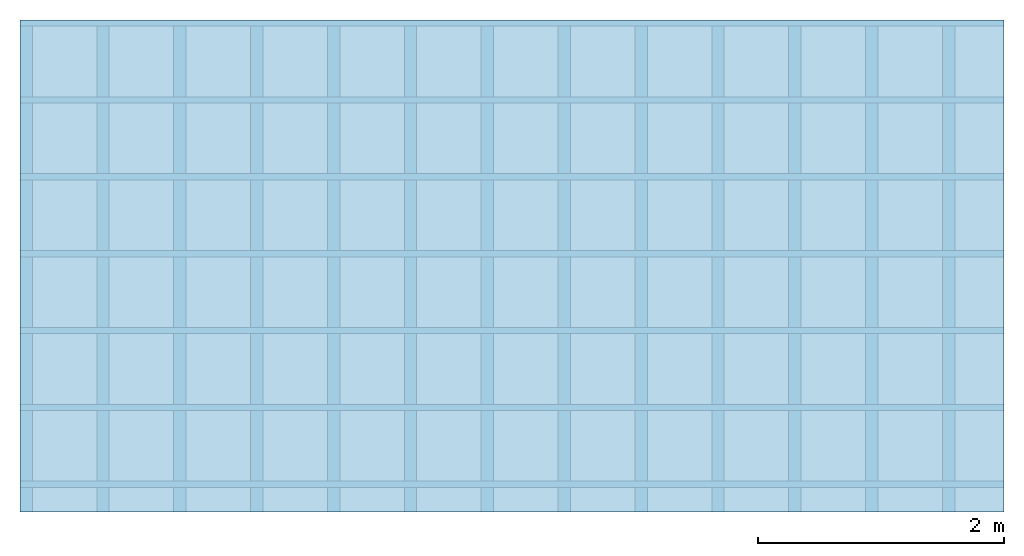
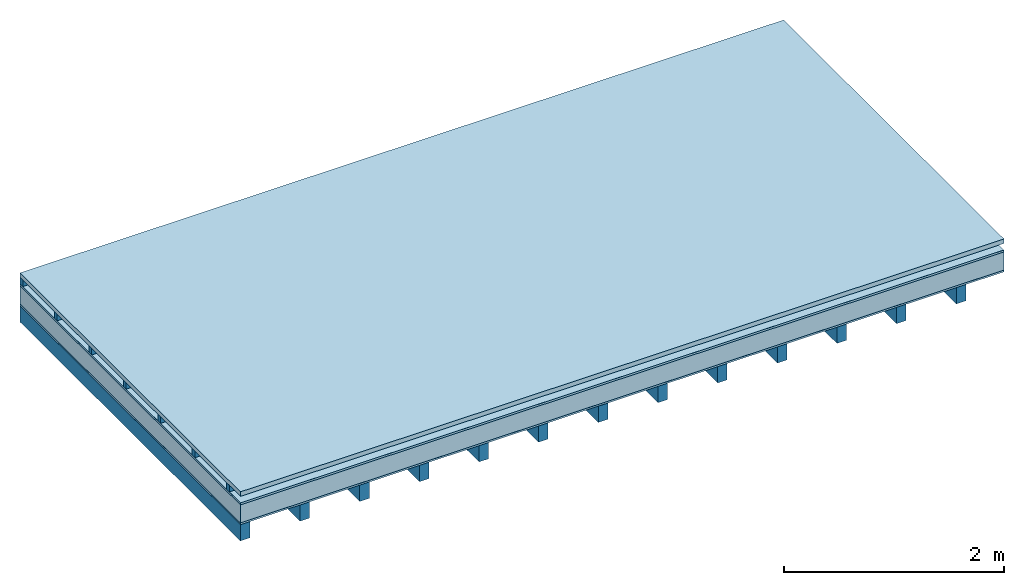
# One storey: 6 plates, 2 members, 1 element without a shape of its own.
"""IFC4 building model written with IfcOpenShell, lengths in metres."""

import ifcopenshell
import ifcopenshell.guid

model = None  # the IFC model being written
_history = None  # IfcOwnerHistory: only IFC2X3 demands one
_inside = {}  # id of a spatial element -> (the spatial element, [elements in it])
_under = {}  # id of a project, library or spatial element -> (it, [spatial elements below it])
_declared = {}  # id of a project -> (the project, [libraries it declares])
_typed = {}  # id of a type object -> (the type object, [elements of that type])
_made_of = {}  # id of a material, layer set ... -> (it, [elements and type objects made of it])


def new_model(schema):
    """Start an empty IFC model of exactly this schema.

    Asked for "IFC4X3", IfcOpenShell would pick the latest addendum, in which some entities
    have other attributes; the version numbers below select the first issue.
    IFC2X3 requires an IfcOwnerHistory on every rooted entity: one is made here for all.
    """
    global model, _history
    if schema == "IFC4X3":
        model = ifcopenshell.file(schema_version=(4, 3, 0, 0))
    else:
        model = ifcopenshell.file(schema=schema)
    _inside.clear()
    _under.clear()
    _declared.clear()
    _typed.clear()
    _made_of.clear()
    _history = None
    if model.schema == "IFC2X3":
        org = make("IfcOrganization", Name="unknown")
        user = make(
            "IfcPersonAndOrganization",
            ThePerson=make("IfcPerson", FamilyName="unknown"),
            TheOrganization=org,
        )
        app = make(
            "IfcApplication",
            ApplicationDeveloper=org,
            Version="unknown",
            ApplicationFullName="unknown",
            ApplicationIdentifier="unknown",
        )
        _history = make(
            "IfcOwnerHistory",
            OwningUser=user,
            OwningApplication=app,
            ChangeAction="ADDED",
            CreationDate=0,
        )
    return model


def make(cls, **values):
    """One entity of the class cls with the attributes given. An attribute that is None is left unset."""
    return model.create_entity(
        cls, **{name: value for name, value in values.items() if value is not None}
    )


def rooted(cls, **values):
    """An entity with a GlobalId (a new one), such as an element, a storey or a relation."""
    return make(cls, GlobalId=ifcopenshell.guid.new(), OwnerHistory=_history, **values)


def si_unit(unit_type, name, prefix=None):
    """IfcSIUnit, for example si_unit("LENGTHUNIT", "METRE", prefix="MILLI")."""
    return make("IfcSIUnit", UnitType=unit_type, Prefix=prefix, Name=name)


def derived_unit(unit_type, elements):
    """IfcDerivedUnit: a product of units, each with its exponent."""
    return make(
        "IfcDerivedUnit",
        Elements=[
            make("IfcDerivedUnitElement", Unit=unit, Exponent=power)
            for unit, power in elements
        ],
        UnitType=unit_type,
    )


def assignment(units):
    """IfcUnitAssignment: the units of a project."""
    return None if units is None else make("IfcUnitAssignment", Units=units)


def point(xyz):
    """IfcCartesianPoint."""
    return None if xyz is None else make("IfcCartesianPoint", Coordinates=xyz)


def direction(xyz):
    """IfcDirection."""
    return None if xyz is None else make("IfcDirection", DirectionRatios=xyz)


def frame(location, z_axis=None, x_axis=None):
    """IfcAxis2Placement3D, a coordinate frame: its origin and axes. An axis left out is left unset."""
    return make(
        "IfcAxis2Placement3D",
        Location=point(location),
        Axis=direction(z_axis),
        RefDirection=direction(x_axis),
    )


def frame_2d(location, x_axis=None):
    """IfcAxis2Placement2D, a coordinate frame in the plane: its origin and x axis."""
    return make(
        "IfcAxis2Placement2D", Location=point(location), RefDirection=direction(x_axis)
    )


def origin():
    """The frame at (0, 0, 0) with its axes left unset."""
    return frame((0.0, 0.0, 0.0))


def origin_with_axes():
    """The frame at (0, 0, 0) with the z axis (0, 0, 1) and the x axis (1, 0, 0) written out."""
    return frame((0.0, 0.0, 0.0), z_axis=(0.0, 0.0, 1.0), x_axis=(1.0, 0.0, 0.0))


def place(relative_to, where):
    """IfcLocalPlacement: puts the frame where relative to a parent placement (None: the world)."""
    return make(
        "IfcLocalPlacement", PlacementRelTo=relative_to, RelativePlacement=where
    )


def context(
    kind, dimensions, precision=None, world=None, true_north=None, identifier=None
):
    """IfcGeometricRepresentationContext, for example the 3D "Model" context."""
    return make(
        "IfcGeometricRepresentationContext",
        ContextIdentifier=identifier,
        ContextType=kind,
        CoordinateSpaceDimension=dimensions,
        Precision=precision,
        WorldCoordinateSystem=world,
        TrueNorth=true_north,
    )


def project(units=None, contexts=None):
    """IfcProject with its units and contexts."""
    return rooted(
        "IfcProject",
        Name="project",
        RepresentationContexts=contexts,
        UnitsInContext=assignment(units),
    )


def spatial(cls, under=None, at=None, **own):
    """A site, building, storey or space (cls), placed at a placement, below another one or the project."""
    s = rooted(cls, ObjectPlacement=at, **own)
    if under is not None:
        _under.setdefault(under.id(), (under, []))[1].append(s)
    return s


def profile(cls, at=None, kind="AREA", **sizes):
    """A parametric profile (cls). Its sizes go by their IFC names, for example OverallWidth=200.0."""
    return make(cls, ProfileType=kind, Position=at, **sizes)


def rectangle(**sizes):
    """IfcRectangleProfileDef."""
    return profile("IfcRectangleProfileDef", **sizes)


def extrude(swept, where, along, depth):
    """IfcExtrudedAreaSolid: the profile swept, set in the frame where, extruded along a direction by depth."""
    return make(
        "IfcExtrudedAreaSolid",
        SweptArea=swept,
        Position=where,
        ExtrudedDirection=direction(along),
        Depth=depth,
    )


def shape(context_of_items, identifier, shape_type, items):
    """IfcShapeRepresentation: the items that make up one representation, for example the "Body"."""
    return make(
        "IfcShapeRepresentation",
        ContextOfItems=context_of_items,
        RepresentationIdentifier=identifier,
        RepresentationType=shape_type,
        Items=items,
    )


def material(Name=None, Category=None):
    """IfcMaterial."""
    return make("IfcMaterial", Name=Name, Category=Category)


def layer(
    of_material, thickness, ventilated=None, Name=None, Category=None, Priority=None
):
    """IfcMaterialLayer: one layer of a wall or slab, of a material (None: an air gap)."""
    return make(
        "IfcMaterialLayer",
        Material=of_material,
        LayerThickness=thickness,
        IsVentilated=ventilated,
        Name=Name,
        Category=Category,
        Priority=Priority,
    )


def layer_set(layers, Name=None):
    """IfcMaterialLayerSet."""
    return make("IfcMaterialLayerSet", MaterialLayers=layers, LayerSetName=Name)


def made_of(thing, what):
    """Note that an element or type object is made of a material, layer set ...; save() writes the relation."""
    if what is not None:
        _made_of.setdefault(what.id(), (what, []))[1].append(thing)
    return thing


def type_object(cls, material=None, **own):
    """A type object (cls), such as IfcWallType, which elements share."""
    return made_of(rooted(cls, **own), material)


def element(
    cls,
    number,
    at=None,
    inside=None,
    cuts=None,
    type_object=None,
    material=None,
    context=None,
    identifier="Body",
    shape_type=None,
    held_by="IfcProductDefinitionShape",
    body=None,
    shapes=None,
    **own,
):
    """One element of the class cls, such as IfcWall. Its Tag is "e" and its number.

    at: its placement. inside: the storey or other place that contains it. cuts: it is an
    opening in that element (IfcRelVoidsElement). A single representation is given by context,
    identifier, shape_type and body (its items); several are given by shapes. held_by: the class
    of the entity that holds the representations. save() writes the other relations.
    """
    e = rooted(cls, Tag="e%d" % number, ObjectPlacement=at, **own)
    if body is not None:
        shapes = [shape(context, identifier, shape_type, body)]
    if shapes is not None:
        e.Representation = make(held_by, Representations=shapes)
    if inside is not None:
        _inside.setdefault(inside.id(), (inside, []))[1].append(e)
    if cuts is not None:
        rooted(
            "IfcRelVoidsElement", RelatingBuildingElement=cuts, RelatedOpeningElement=e
        )
    if type_object is not None:
        _typed.setdefault(type_object.id(), (type_object, []))[1].append(e)
    return made_of(e, material)


def aggregate(whole, parts):
    """IfcRelAggregates: a whole, such as a stair, and the parts it consists of."""
    return rooted("IfcRelAggregates", RelatingObject=whole, RelatedObjects=parts)


def save(model, path):
    """Write the relations noted so far, then the file.

    IfcRelAggregates (storeys below a building ...), IfcRelContainedInSpatialStructure (elements
    in a storey), IfcRelDefinesByType, IfcRelAssociatesMaterial and IfcRelDeclares: one each for
    every whole, place, type object, material and project.
    """
    for whole, parts in _under.values():
        aggregate(whole, parts)
    for where, things in _inside.values():
        rooted(
            "IfcRelContainedInSpatialStructure",
            RelatedElements=things,
            RelatingStructure=where,
        )
    for kind, things in _typed.values():
        rooted("IfcRelDefinesByType", RelatedObjects=things, RelatingType=kind)
    for what, things in _made_of.values():
        rooted("IfcRelAssociatesMaterial", RelatedObjects=things, RelatingMaterial=what)
    for by, libraries in _declared.values():
        rooted("IfcRelDeclares", RelatingContext=by, RelatedDefinitions=libraries)
    model.write(path)


model = new_model("IFC4")

# Units and contexts
plan_context = context("Plan", 3, precision=1e-05, world=origin(), true_north=direction((0.0, 1.0)))
model_context = context("Model", 3, precision=1e-05, world=origin(), true_north=direction((0.0, 1.0)))
ifc_project = project(units=[si_unit("LENGTHUNIT", "METRE"), derived_unit("SOUNDPRESSUREUNIT", [(si_unit("PRESSUREUNIT", "PASCAL", prefix="MICRO"), 0)]), si_unit("ENERGYUNIT", "JOULE", prefix="MEGA"), si_unit("MASSUNIT", "GRAM", prefix="KILO"), derived_unit("THERMALTRANSMITTANCEUNIT", [(si_unit("POWERUNIT", "WATT"), 1), (si_unit("AREAUNIT", "SQUARE_METRE"), -1), (si_unit("THERMODYNAMICTEMPERATUREUNIT", "KELVIN"), -1)]), derived_unit("AREADENSITYUNIT", [(si_unit("MASSUNIT", "GRAM", prefix="KILO"), 1), (si_unit("AREAUNIT", "SQUARE_METRE"), -1)]), derived_unit("USERDEFINED", [(si_unit("ENERGYUNIT", "JOULE", prefix="MEGA"), 1), (si_unit("AREAUNIT", "SQUARE_METRE"), -1)])], contexts=[plan_context, model_context])

# Site, building, storey
site = spatial("IfcSite", under=ifc_project)
building_placement = place(None, origin())
building = spatial("IfcBuilding", under=site, at=building_placement)
storey_placement = place(building_placement, origin())
storey = spatial("IfcBuildingStorey", under=building, at=storey_placement)

# Slab, members, plates
ifc_material_1 = material(Name="Roof tiles", Category="03.015")
ifc_layer_1 = layer(ifc_material_1, 0.05, Name="Roofing")
ifc_layer_2 = layer(None, 0.072, Name="Battens / profiles")
ifc_material_2 = material(Name="Roofing underlay", Category="09.008")
ifc_layer_3 = layer(ifc_material_2, 0.00018, Name="Under the roof")
ifc_material_3 = material(Category="10.009")
ifc_layer_4 = layer(ifc_material_3, 0.022, Name="Exterior insulation layer 2")
ifc_material_4 = material(Category="10.008")
ifc_layer_5 = layer(ifc_material_4, 0.2, Name="Exterior insulation layer 1")
ifc_material_5 = material(Name="Vapor barrier polyethylene (PE)", Category="09.002")
ifc_layer_6 = layer(ifc_material_5, 0.00018, Name="above 1st layer")
ifc_material_6 = material(Name="Boards with edges", Category="07.009")
ifc_layer_7 = layer(ifc_material_6, 0.02, Name="Sub-floor")
ifc_material_7 = material(Name="of the art")
ifc_layer_8 = layer(ifc_material_7, 0.0, Name="Bond")
ifc_layer_9 = layer(None, 0.18, Name="Supporting structure")
ifc_layer_set = layer_set([ifc_layer_1, ifc_layer_2, ifc_layer_3, ifc_layer_4, ifc_layer_5, ifc_layer_6, ifc_layer_7, ifc_layer_8, ifc_layer_9])
slab_type = type_object("IfcSlabType", Name="E0168", PredefinedType="NOTDEFINED", material=ifc_layer_set)
slab_placement = place(None, frame((0.0, 0.0, 0.0), z_axis=(0.0, 0.0, -1.0), x_axis=(1.0, 0.0, 0.0)))
slab = element("IfcSlab", 1, at=slab_placement, inside=storey, type_object=slab_type, material=ifc_layer_set, Name="Slab #1")
ifc_material_8 = material()
member_1_placement = place(slab_placement, origin())
member_1 = element("IfcMember", 2, at=member_1_placement, material=ifc_material_8, Name="Battens / profiles", context=plan_context, shape_type="SweptSolid", body=[
    extrude(rectangle(XDim=0.05, YDim=0.072, at=frame_2d((0.025, 0.036), x_axis=(1.0, 0.0))), frame((0.0, 0.0, 0.05), z_axis=(1.0, 0.0, 0.0), x_axis=(0.0, 1.0, 0.0)), (0.0, 0.0, 1.0), 8.0),
    extrude(rectangle(XDim=0.05, YDim=0.072, at=frame_2d((0.025, 0.036), x_axis=(1.0, 0.0))), frame((0.0, 0.625, 0.05), z_axis=(1.0, 0.0, 0.0), x_axis=(0.0, 1.0, 0.0)), (0.0, 0.0, 1.0), 8.0),
    extrude(rectangle(XDim=0.05, YDim=0.072, at=frame_2d((0.025, 0.036), x_axis=(1.0, 0.0))), frame((0.0, 1.25, 0.05), z_axis=(1.0, 0.0, 0.0), x_axis=(0.0, 1.0, 0.0)), (0.0, 0.0, 1.0), 8.0),
    extrude(rectangle(XDim=0.05, YDim=0.072, at=frame_2d((0.025, 0.036), x_axis=(1.0, 0.0))), frame((0.0, 1.875, 0.05), z_axis=(1.0, 0.0, 0.0), x_axis=(0.0, 1.0, 0.0)), (0.0, 0.0, 1.0), 8.0),
    extrude(rectangle(XDim=0.05, YDim=0.072, at=frame_2d((0.025, 0.036), x_axis=(1.0, 0.0))), frame((0.0, 2.5, 0.05), z_axis=(1.0, 0.0, 0.0), x_axis=(0.0, 1.0, 0.0)), (0.0, 0.0, 1.0), 8.0),
    extrude(rectangle(XDim=0.05, YDim=0.072, at=frame_2d((0.025, 0.036), x_axis=(1.0, 0.0))), frame((0.0, 3.125, 0.05), z_axis=(1.0, 0.0, 0.0), x_axis=(0.0, 1.0, 0.0)), (0.0, 0.0, 1.0), 8.0),
    extrude(rectangle(XDim=0.05, YDim=0.072, at=frame_2d((0.025, 0.036), x_axis=(1.0, 0.0))), frame((0.0, 3.75, 0.05), z_axis=(1.0, 0.0, 0.0), x_axis=(0.0, 1.0, 0.0)), (0.0, 0.0, 1.0), 8.0),
])
ifc_material_9 = material()
member_2_placement = place(slab_placement, origin())
member_2 = element("IfcMember", 3, at=member_2_placement, material=ifc_material_9, Name="Supporting structure", context=plan_context, shape_type="SweptSolid", body=[
    extrude(rectangle(XDim=0.1, YDim=0.18, at=frame_2d((0.05, 0.09), x_axis=(1.0, 0.0))), frame((0.0, 4.0, 0.36436), z_axis=(0.0, -1.0, 0.0), x_axis=(1.0, 0.0, 0.0)), (0.0, 0.0, 1.0), 4.0),
    extrude(rectangle(XDim=0.1, YDim=0.18, at=frame_2d((0.05, 0.09), x_axis=(1.0, 0.0))), frame((0.625, 4.0, 0.36436), z_axis=(0.0, -1.0, 0.0), x_axis=(1.0, 0.0, 0.0)), (0.0, 0.0, 1.0), 4.0),
    extrude(rectangle(XDim=0.1, YDim=0.18, at=frame_2d((0.05, 0.09), x_axis=(1.0, 0.0))), frame((1.25, 4.0, 0.36436), z_axis=(0.0, -1.0, 0.0), x_axis=(1.0, 0.0, 0.0)), (0.0, 0.0, 1.0), 4.0),
    extrude(rectangle(XDim=0.1, YDim=0.18, at=frame_2d((0.05, 0.09), x_axis=(1.0, 0.0))), frame((1.875, 4.0, 0.36436), z_axis=(0.0, -1.0, 0.0), x_axis=(1.0, 0.0, 0.0)), (0.0, 0.0, 1.0), 4.0),
    extrude(rectangle(XDim=0.1, YDim=0.18, at=frame_2d((0.05, 0.09), x_axis=(1.0, 0.0))), frame((2.5, 4.0, 0.36436), z_axis=(0.0, -1.0, 0.0), x_axis=(1.0, 0.0, 0.0)), (0.0, 0.0, 1.0), 4.0),
    extrude(rectangle(XDim=0.1, YDim=0.18, at=frame_2d((0.05, 0.09), x_axis=(1.0, 0.0))), frame((3.125, 4.0, 0.36436), z_axis=(0.0, -1.0, 0.0), x_axis=(1.0, 0.0, 0.0)), (0.0, 0.0, 1.0), 4.0),
    extrude(rectangle(XDim=0.1, YDim=0.18, at=frame_2d((0.05, 0.09), x_axis=(1.0, 0.0))), frame((3.75, 4.0, 0.36436), z_axis=(0.0, -1.0, 0.0), x_axis=(1.0, 0.0, 0.0)), (0.0, 0.0, 1.0), 4.0),
    extrude(rectangle(XDim=0.1, YDim=0.18, at=frame_2d((0.05, 0.09), x_axis=(1.0, 0.0))), frame((4.375, 4.0, 0.36436), z_axis=(0.0, -1.0, 0.0), x_axis=(1.0, 0.0, 0.0)), (0.0, 0.0, 1.0), 4.0),
    extrude(rectangle(XDim=0.1, YDim=0.18, at=frame_2d((0.05, 0.09), x_axis=(1.0, 0.0))), frame((5.0, 4.0, 0.36436), z_axis=(0.0, -1.0, 0.0), x_axis=(1.0, 0.0, 0.0)), (0.0, 0.0, 1.0), 4.0),
    extrude(rectangle(XDim=0.1, YDim=0.18, at=frame_2d((0.05, 0.09), x_axis=(1.0, 0.0))), frame((5.625, 4.0, 0.36436), z_axis=(0.0, -1.0, 0.0), x_axis=(1.0, 0.0, 0.0)), (0.0, 0.0, 1.0), 4.0),
    extrude(rectangle(XDim=0.1, YDim=0.18, at=frame_2d((0.05, 0.09), x_axis=(1.0, 0.0))), frame((6.25, 4.0, 0.36436), z_axis=(0.0, -1.0, 0.0), x_axis=(1.0, 0.0, 0.0)), (0.0, 0.0, 1.0), 4.0),
    extrude(rectangle(XDim=0.1, YDim=0.18, at=frame_2d((0.05, 0.09), x_axis=(1.0, 0.0))), frame((6.875, 4.0, 0.36436), z_axis=(0.0, -1.0, 0.0), x_axis=(1.0, 0.0, 0.0)), (0.0, 0.0, 1.0), 4.0),
    extrude(rectangle(XDim=0.1, YDim=0.18, at=frame_2d((0.05, 0.09), x_axis=(1.0, 0.0))), frame((7.5, 4.0, 0.36436), z_axis=(0.0, -1.0, 0.0), x_axis=(1.0, 0.0, 0.0)), (0.0, 0.0, 1.0), 4.0),
])
plate_1_placement = place(slab_placement, origin())
plate_1 = element("IfcPlate", 4, at=plate_1_placement, material=ifc_material_1, Name="Roofing", context=plan_context, shape_type="SweptSolid", body=[
    extrude(rectangle(XDim=8.0, YDim=4.0, at=frame_2d((4.0, 2.0), x_axis=(1.0, 0.0))), origin_with_axes(), (0.0, 0.0, 1.0), 0.05),
])
plate_2_placement = place(slab_placement, origin())
plate_2 = element("IfcPlate", 5, at=plate_2_placement, material=ifc_material_2, Name="Under the roof", context=plan_context, shape_type="SweptSolid", body=[
    extrude(rectangle(XDim=8.0, YDim=4.0, at=frame_2d((4.0, 2.0), x_axis=(1.0, 0.0))), frame((0.0, 0.0, 0.122), z_axis=(0.0, 0.0, 1.0), x_axis=(1.0, 0.0, 0.0)), (0.0, 0.0, 1.0), 0.00018),
])
plate_3_placement = place(slab_placement, origin())
plate_3 = element("IfcPlate", 6, at=plate_3_placement, material=ifc_material_3, Name="Exterior insulation layer 2", context=plan_context, shape_type="SweptSolid", body=[
    extrude(rectangle(XDim=8.0, YDim=4.0, at=frame_2d((4.0, 2.0), x_axis=(1.0, 0.0))), frame((0.0, 0.0, 0.12218), z_axis=(0.0, 0.0, 1.0), x_axis=(1.0, 0.0, 0.0)), (0.0, 0.0, 1.0), 0.022),
])
plate_4_placement = place(slab_placement, origin())
plate_4 = element("IfcPlate", 7, at=plate_4_placement, material=ifc_material_4, Name="Exterior insulation layer 1", context=plan_context, shape_type="SweptSolid", body=[
    extrude(rectangle(XDim=8.0, YDim=4.0, at=frame_2d((4.0, 2.0), x_axis=(1.0, 0.0))), frame((0.0, 0.0, 0.14418), z_axis=(0.0, 0.0, 1.0), x_axis=(1.0, 0.0, 0.0)), (0.0, 0.0, 1.0), 0.2),
])
plate_5_placement = place(slab_placement, origin())
plate_5 = element("IfcPlate", 8, at=plate_5_placement, material=ifc_material_5, Name="above 1st layer", context=plan_context, shape_type="SweptSolid", body=[
    extrude(rectangle(XDim=8.0, YDim=4.0, at=frame_2d((4.0, 2.0), x_axis=(1.0, 0.0))), frame((0.0, 0.0, 0.34418), z_axis=(0.0, 0.0, 1.0), x_axis=(1.0, 0.0, 0.0)), (0.0, 0.0, 1.0), 0.00018),
])
plate_6_placement = place(slab_placement, origin())
plate_6 = element("IfcPlate", 9, at=plate_6_placement, material=ifc_material_6, Name="Sub-floor", context=plan_context, shape_type="SweptSolid", body=[
    extrude(rectangle(XDim=8.0, YDim=4.0, at=frame_2d((4.0, 2.0), x_axis=(1.0, 0.0))), frame((0.0, 0.0, 0.34436), z_axis=(0.0, 0.0, 1.0), x_axis=(1.0, 0.0, 0.0)), (0.0, 0.0, 1.0), 0.02),
])
aggregate(slab, [plate_1, member_1, plate_2, plate_3, plate_4, plate_5, plate_6, member_2])

save(model, "model.ifc")
